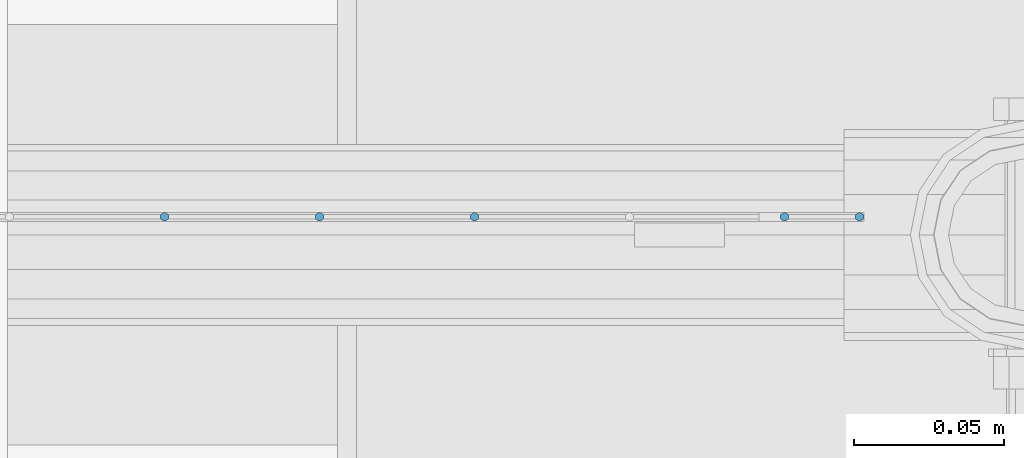
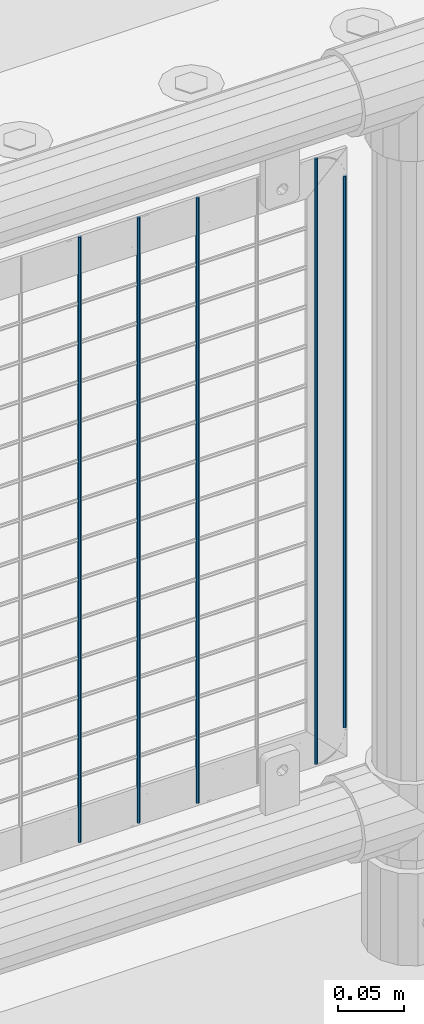
# One storey, part 57 of 193: 5 columns.
"""IFC2X3 building model written with IfcOpenShell, lengths in millimetres."""

import ifcopenshell
import ifcopenshell.guid

model = None  # the IFC model being written
_history = None  # IfcOwnerHistory: only IFC2X3 demands one
_inside = {}  # id of a spatial element -> (the spatial element, [elements in it])
_under = {}  # id of a project, library or spatial element -> (it, [spatial elements below it])
_declared = {}  # id of a project -> (the project, [libraries it declares])
_typed = {}  # id of a type object -> (the type object, [elements of that type])
_made_of = {}  # id of a material, layer set ... -> (it, [elements and type objects made of it])


def new_model(schema):
    """Start an empty IFC model of exactly this schema.

    Asked for "IFC4X3", IfcOpenShell would pick the latest addendum, in which some entities
    have other attributes; the version numbers below select the first issue.
    IFC2X3 requires an IfcOwnerHistory on every rooted entity: one is made here for all.
    """
    global model, _history
    if schema == "IFC4X3":
        model = ifcopenshell.file(schema_version=(4, 3, 0, 0))
    else:
        model = ifcopenshell.file(schema=schema)
    _inside.clear()
    _under.clear()
    _declared.clear()
    _typed.clear()
    _made_of.clear()
    _history = None
    if model.schema == "IFC2X3":
        org = make("IfcOrganization", Name="unknown")
        user = make(
            "IfcPersonAndOrganization",
            ThePerson=make("IfcPerson", FamilyName="unknown"),
            TheOrganization=org,
        )
        app = make(
            "IfcApplication",
            ApplicationDeveloper=org,
            Version="unknown",
            ApplicationFullName="unknown",
            ApplicationIdentifier="unknown",
        )
        _history = make(
            "IfcOwnerHistory",
            OwningUser=user,
            OwningApplication=app,
            ChangeAction="ADDED",
            CreationDate=0,
        )
    return model


def make(cls, **values):
    """One entity of the class cls with the attributes given. An attribute that is None is left unset."""
    return model.create_entity(
        cls, **{name: value for name, value in values.items() if value is not None}
    )


def rooted(cls, **values):
    """An entity with a GlobalId (a new one), such as an element, a storey or a relation."""
    return make(cls, GlobalId=ifcopenshell.guid.new(), OwnerHistory=_history, **values)


def si_unit(unit_type, name, prefix=None):
    """IfcSIUnit, for example si_unit("LENGTHUNIT", "METRE", prefix="MILLI")."""
    return make("IfcSIUnit", UnitType=unit_type, Prefix=prefix, Name=name)


def assignment(units):
    """IfcUnitAssignment: the units of a project."""
    return None if units is None else make("IfcUnitAssignment", Units=units)


def point(xyz):
    """IfcCartesianPoint."""
    return None if xyz is None else make("IfcCartesianPoint", Coordinates=xyz)


def direction(xyz):
    """IfcDirection."""
    return None if xyz is None else make("IfcDirection", DirectionRatios=xyz)


def frame(location, z_axis=None, x_axis=None):
    """IfcAxis2Placement3D, a coordinate frame: its origin and axes. An axis left out is left unset."""
    return make(
        "IfcAxis2Placement3D",
        Location=point(location),
        Axis=direction(z_axis),
        RefDirection=direction(x_axis),
    )


def origin_with_axes():
    """The frame at (0, 0, 0) with the z axis (0, 0, 1) and the x axis (1, 0, 0) written out."""
    return frame((0.0, 0.0, 0.0), z_axis=(0.0, 0.0, 1.0), x_axis=(1.0, 0.0, 0.0))


def place(relative_to, where):
    """IfcLocalPlacement: puts the frame where relative to a parent placement (None: the world)."""
    return make(
        "IfcLocalPlacement", PlacementRelTo=relative_to, RelativePlacement=where
    )


def context(
    kind, dimensions, precision=None, world=None, true_north=None, identifier=None
):
    """IfcGeometricRepresentationContext, for example the 3D "Model" context."""
    return make(
        "IfcGeometricRepresentationContext",
        ContextIdentifier=identifier,
        ContextType=kind,
        CoordinateSpaceDimension=dimensions,
        Precision=precision,
        WorldCoordinateSystem=world,
        TrueNorth=true_north,
    )


def subcontext(parent, identifier, kind, view, scale=None):
    """IfcGeometricRepresentationSubContext, for example "Body" below "Model"."""
    return make(
        "IfcGeometricRepresentationSubContext",
        ContextIdentifier=identifier,
        ContextType=kind,
        ParentContext=parent,
        TargetScale=scale,
        TargetView=view,
    )


def project(units=None, contexts=None):
    """IfcProject with its units and contexts."""
    return rooted(
        "IfcProject",
        Name="project",
        RepresentationContexts=contexts,
        UnitsInContext=assignment(units),
    )


def spatial(cls, under=None, at=None, **own):
    """A site, building, storey or space (cls), placed at a placement, below another one or the project."""
    s = rooted(cls, ObjectPlacement=at, **own)
    if under is not None:
        _under.setdefault(under.id(), (under, []))[1].append(s)
    return s


def faces_of(points, faces, orient=None, outer=None):
    """IfcFace entities. A face is a list of loops; a loop is a list of indices into points, from 0.

    orient and outer hold one flag for each loop. By default every Orientation is true, the
    first loop of a face is its IfcFaceOuterBound and the others are IfcFaceBound.
    """
    made = []
    for i, loops in enumerate(faces):
        bounds = []
        for j, loop in enumerate(loops):
            is_outer = j == 0 if outer is None else outer[i][j]
            bounds.append(
                make(
                    "IfcFaceOuterBound" if is_outer else "IfcFaceBound",
                    Bound=make("IfcPolyLoop", Polygon=[points[k] for k in loop]),
                    Orientation=True if orient is None else orient[i][j],
                )
            )
        made.append(make("IfcFace", Bounds=bounds))
    return made


def faceted_brep(points, faces, orient=None, outer=None, voids=None):
    """IfcFacetedBrep: a solid bounded by flat faces; with voids (closed shells), ...WithVoids."""
    shared = [point(p) for p in points]
    hull = make("IfcClosedShell", CfsFaces=faces_of(shared, faces, orient, outer))
    if voids is None:
        return make("IfcFacetedBrep", Outer=hull)
    return make(
        "IfcFacetedBrepWithVoids",
        Outer=hull,
        Voids=[
            make(cls, CfsFaces=faces_of(shared, fs, o, b)) for cls, fs, o, b in voids
        ],
    )


def shape(context_of_items, identifier, shape_type, items):
    """IfcShapeRepresentation: the items that make up one representation, for example the "Body"."""
    return make(
        "IfcShapeRepresentation",
        ContextOfItems=context_of_items,
        RepresentationIdentifier=identifier,
        RepresentationType=shape_type,
        Items=items,
    )


def material(Name=None, Category=None):
    """IfcMaterial."""
    return make("IfcMaterial", Name=Name, Category=Category)


def made_of(thing, what):
    """Note that an element or type object is made of a material, layer set ...; save() writes the relation."""
    if what is not None:
        _made_of.setdefault(what.id(), (what, []))[1].append(thing)
    return thing


def type_object(cls, material=None, **own):
    """A type object (cls), such as IfcWallType, which elements share."""
    return made_of(rooted(cls, **own), material)


def element(
    cls,
    number,
    at=None,
    inside=None,
    cuts=None,
    type_object=None,
    material=None,
    context=None,
    identifier="Body",
    shape_type=None,
    held_by="IfcProductDefinitionShape",
    body=None,
    shapes=None,
    **own,
):
    """One element of the class cls, such as IfcWall. Its Tag is "e" and its number.

    at: its placement. inside: the storey or other place that contains it. cuts: it is an
    opening in that element (IfcRelVoidsElement). A single representation is given by context,
    identifier, shape_type and body (its items); several are given by shapes. held_by: the class
    of the entity that holds the representations. save() writes the other relations.
    """
    e = rooted(cls, Tag="e%d" % number, ObjectPlacement=at, **own)
    if body is not None:
        shapes = [shape(context, identifier, shape_type, body)]
    if shapes is not None:
        e.Representation = make(held_by, Representations=shapes)
    if inside is not None:
        _inside.setdefault(inside.id(), (inside, []))[1].append(e)
    if cuts is not None:
        rooted(
            "IfcRelVoidsElement", RelatingBuildingElement=cuts, RelatedOpeningElement=e
        )
    if type_object is not None:
        _typed.setdefault(type_object.id(), (type_object, []))[1].append(e)
    return made_of(e, material)


def aggregate(whole, parts):
    """IfcRelAggregates: a whole, such as a stair, and the parts it consists of."""
    return rooted("IfcRelAggregates", RelatingObject=whole, RelatedObjects=parts)


def save(model, path):
    """Write the relations noted so far, then the file.

    IfcRelAggregates (storeys below a building ...), IfcRelContainedInSpatialStructure (elements
    in a storey), IfcRelDefinesByType, IfcRelAssociatesMaterial and IfcRelDeclares: one each for
    every whole, place, type object, material and project.
    """
    for whole, parts in _under.values():
        aggregate(whole, parts)
    for where, things in _inside.values():
        rooted(
            "IfcRelContainedInSpatialStructure",
            RelatedElements=things,
            RelatingStructure=where,
        )
    for kind, things in _typed.values():
        rooted("IfcRelDefinesByType", RelatedObjects=things, RelatingType=kind)
    for what, things in _made_of.values():
        rooted("IfcRelAssociatesMaterial", RelatedObjects=things, RelatingMaterial=what)
    for by, libraries in _declared.values():
        rooted("IfcRelDeclares", RelatingContext=by, RelatedDefinitions=libraries)
    model.write(path)


model = new_model("IFC2X3")

# Units and contexts
model_context = context("Model", 3, precision=1e-05, world=origin_with_axes())
body_context = subcontext(model_context, "Body", "Model", "MODEL_VIEW")
ifc_project = project(units=[si_unit("LENGTHUNIT", "METRE", prefix="MILLI"), si_unit("AREAUNIT", "SQUARE_METRE"), si_unit("VOLUMEUNIT", "CUBIC_METRE"), si_unit("MASSUNIT", "GRAM", prefix="KILO"), si_unit("TIMEUNIT", "SECOND"), si_unit("PLANEANGLEUNIT", "RADIAN"), si_unit("SOLIDANGLEUNIT", "STERADIAN"), si_unit("THERMODYNAMICTEMPERATUREUNIT", "DEGREE_CELSIUS"), si_unit("LUMINOUSINTENSITYUNIT", "LUMEN")], contexts=[model_context])

# Site, building, storey
site_placement = place(None, origin_with_axes())
site = spatial("IfcSite", under=ifc_project, at=site_placement, CompositionType="ELEMENT")
building_placement = place(site_placement, origin_with_axes())
building = spatial("IfcBuilding", under=site, at=building_placement, Name="Standard", CompositionType="ELEMENT")
storey_placement = place(building_placement, origin_with_axes())
storey = spatial("IfcBuildingStorey", under=building, at=storey_placement, Name="Undefined", CompositionType="ELEMENT", Elevation=0.0)

# Columns
ifc_material = material(Name="Misc_Undefined")
column_type = type_object("IfcColumnType", Name="D3", PredefinedType="NOTDEFINED")
for number, where, z_axis, x_axis in (
    (1, (-40354.315, 28670.5, 353.02), (-1.0, 0.0, 0.0), (0.0, 0.0, 1.0)),
    (2, (-40405.97, 28670.5, 353.02), (-1.0, 0.0, 0.0), (0.0, 0.0, 1.0)),
    (3, (-40457.625, 28670.5, 353.02), (-1.0, 0.0, 0.0), (0.0, 0.0, 1.0)),
    (4, (-40251.005, 28670.5, 353.02), (-1.0, 0.0, 0.0), (0.0, 0.0, 1.0)),
):
    element("IfcColumn", number, at=place(storey_placement, frame(where, z_axis=z_axis, x_axis=x_axis)), inside=storey, type_object=column_type, material=ifc_material, ObjectType="D3", context=body_context, shape_type="Brep", body=[
        faceted_brep([(0.0, -1.49999999999636, 3.63797880709171e-12), (0.0, -0.75, -1.29903810567669), (560.0, -0.75, -1.29903810567703), (560.0, -1.5, 0.0), (0.0, 0.75, -1.29903810567669), (560.0, 0.75, -1.29903810567703), (0.0, 1.50000000000364, 7.27595761418343e-12), (560.0, 1.5, 0.0), (0.0, 0.75, 1.29903810567669), (560.0, 0.75, 1.29903810567703), (0.0, -0.75, 1.29903810567669), (560.0, -0.75, 1.29903810567703)], [[[0, 1, 2, 3]], [[1, 4, 5, 2]], [[4, 6, 7, 5]], [[6, 8, 9, 7]], [[8, 10, 11, 9]], [[10, 0, 3, 11]], [[5, 7, 9, 11, 3, 2]], [[10, 8, 6, 4, 1, 0]]]),
    ])
column_placement = place(storey_placement, frame((-40226.0, 28670.5, 378.02), z_axis=(-1.0, 0.0, 0.0), x_axis=(0.0, 0.0, 1.0)))
element("IfcColumn", 5, at=column_placement, inside=storey, type_object=column_type, material=ifc_material, ObjectType="D3", context=body_context, shape_type="Brep", body=[
    faceted_brep([(0.0, -1.49999999999636, 3.63797880709171e-12), (0.0, -0.75, -1.29903810567669), (510.0, -0.75, -1.29903810567703), (510.0, -1.5, 0.0), (0.0, 0.75, -1.29903810567669), (510.0, 0.75, -1.29903810567703), (0.0, 1.50000000000364, 7.27595761418343e-12), (510.0, 1.5, 0.0), (0.0, 0.75, 1.29903810567669), (510.0, 0.75, 1.29903810567703), (0.0, -0.75, 1.29903810567669), (510.0, -0.75, 1.29903810567703)], [[[0, 1, 2, 3]], [[1, 4, 5, 2]], [[4, 6, 7, 5]], [[6, 8, 9, 7]], [[8, 10, 11, 9]], [[10, 0, 3, 11]], [[5, 7, 9, 11, 3, 2]], [[10, 8, 6, 4, 1, 0]]]),
])

save(model, "model.ifc")
